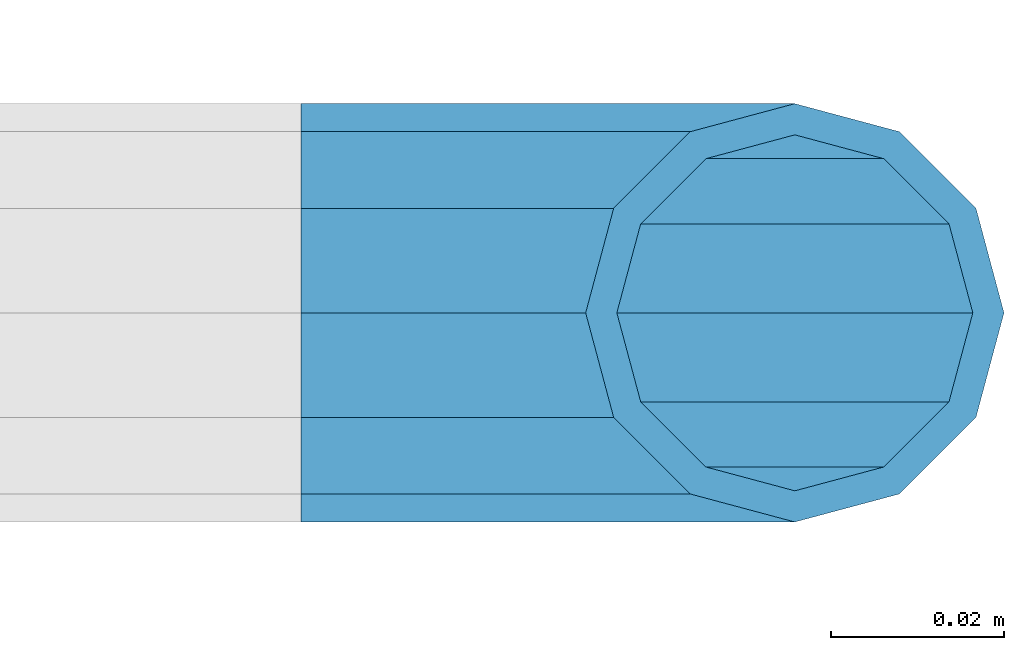
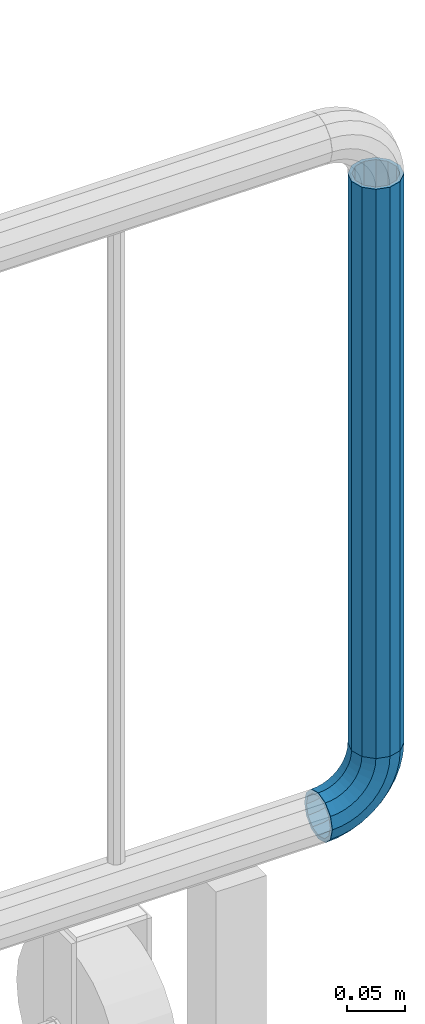
# One storey, part 165 of 247: 1 beam, 1 member.
"""IFC2X3 building model written with IfcOpenShell, lengths in millimetres."""

from ifc_helpers import new_model, si_unit, frame, origin_with_axes, place, context, subcontext, project, spatial, faceted_brep, material, type_object, element, save


model = new_model("IFC2X3")

# Units and contexts
model_context = context("Model", 3, precision=1e-05, world=origin_with_axes())
body_context = subcontext(model_context, "Body", "Model", "MODEL_VIEW")
ifc_project = project(units=[si_unit("LENGTHUNIT", "METRE", prefix="MILLI"), si_unit("AREAUNIT", "SQUARE_METRE"), si_unit("VOLUMEUNIT", "CUBIC_METRE"), si_unit("MASSUNIT", "GRAM", prefix="KILO"), si_unit("TIMEUNIT", "SECOND"), si_unit("PLANEANGLEUNIT", "RADIAN"), si_unit("SOLIDANGLEUNIT", "STERADIAN"), si_unit("THERMODYNAMICTEMPERATUREUNIT", "DEGREE_CELSIUS"), si_unit("LUMINOUSINTENSITYUNIT", "LUMEN")], contexts=[model_context])

# Site, building, storey
site_placement = place(None, origin_with_axes())
site = spatial("IfcSite", under=ifc_project, at=site_placement, CompositionType="ELEMENT")
building_placement = place(site_placement, origin_with_axes())
building = spatial("IfcBuilding", under=site, at=building_placement, Name="Standard", CompositionType="ELEMENT")
storey_placement = place(building_placement, origin_with_axes())
storey = spatial("IfcBuildingStorey", under=building, at=storey_placement, Name="Undefined", CompositionType="ELEMENT", Elevation=0.0)

# Member
ifc_material = material()
member_type = type_object("IfcMemberType", PredefinedType="NOTDEFINED")
member_placement = place(storey_placement, frame((30329.9462613762, 5941.85337247848, 281.650006544463), z_axis=(0.0, -0.999999999999548, -9.5100000000016e-07), x_axis=(-0.707106773186475, 4.52999999771556e-07, -0.707106789186475)))
element("IfcMember", 1, at=member_placement, inside=storey, type_object=member_type, material=ifc_material, context=body_context, shape_type="Brep", body=[
    faceted_brep([(17.0766287656552, -17.0766287656515, 0.0), (14.7887943220521, -14.7887943220485, -12.0749999999998), (19.0945697419556, -11.1113146999705, -12.0749999999998), (20.9963409898264, -13.7288782624128, 0.0), (8.53831438282941, -8.53831438282577, -20.9145135013941), (13.8988340683936, -3.95999805533575, -20.9145135013941), (0.0, 3.63797880709171e-12, -24.1499999999996), (6.80132714696083, 5.80888215174127, -24.1499999999996), (-8.53831438282577, 8.53831438282941, -20.9145135013941), (-0.296179774468328, 15.5777623588219, -20.9145135013941), (-14.7887943220521, 14.7887943220558, -12.0749999999998), (-5.4919154480267, 22.7290790034531, -12.0749999999998), (-17.0766287656552, 17.0766287656588, 0.0), (-7.39368669590112, 25.3466425658989, 0.0), (-14.7887943220521, 14.7887943220558, 12.0749999999998), (-5.4919154480267, 22.7290790034531, 12.0749999999998), (-8.53831438282577, 8.53831438282941, 20.9145135013941), (-0.296179774468328, 15.5777623588219, 20.9145135013941), (0.0, 3.63797880709171e-12, 24.1499999999996), (6.80132714696083, 5.80888215174127, 24.1499999999996), (8.53831438282941, -8.53831438282577, 20.9145135013941), (13.8988340683936, -3.95999805533575, 20.9145135013941), (14.7887943220521, -14.7887943220485, 12.0749999999998), (19.0945697419556, -11.1113146999705, 12.0749999999998), (14.5310443533854, -14.5310443533817, 0.0), (12.5842535535485, -12.5842535535448, 10.2749999999996), (17.2620366843148, -8.58904933077429, 10.2749999999996), (18.8803140815726, -10.8164170826603, 0.0), (7.26552217669087, -7.26552217668723, 17.7968220477705), (12.8408206142667, -2.50376746545953, 17.7968220477705), (0.0, 3.63797880709171e-12, 20.5500000000002), (6.80132714696083, 5.80888215174127, 20.5500000000002), (-7.26552217669087, 7.2655221766945, 17.7968220477705), (0.761833679654956, 14.1215317689421, 17.7968220477705), (-12.5842535535485, 12.5842535535521, 10.2749999999996), (-3.65938239038951, 20.2068136342532, 10.2749999999996), (-14.5310443533817, 14.5310443533854, 0.0), (-5.27765978764728, 22.4341813861465, 0.0), (-12.5842535535485, 12.5842535535521, -10.2749999999996), (-3.65938239038951, 20.2068136342532, -10.2749999999996), (-7.26552217669087, 7.2655221766945, -17.7968220477705), (0.761833679654956, 14.1215317689421, -17.7968220477705), (0.0, 3.63797880709171e-12, -20.5500000000002), (6.80132714696083, 5.80888215174127, -20.5500000000002), (7.26552217669087, -7.26552217668723, -17.7968220477705), (12.8408206142667, -2.50376746545953, -17.7968220477705), (12.5842535535485, -12.5842535535448, -10.2749999999996), (17.2620366843148, -8.58904933077429, -10.2749999999996), (23.922618478784, -8.15268262886457, -12.0749999999998), (25.3914986111849, -11.0355222080434, 0.0), (19.9095633268335, -0.276618428470101, -20.9145135013941), (14.4276280424783, 10.4822853511068, -24.1499999999996), (8.94569275812319, 21.2411891306838, -20.9145135013941), (4.93263760616901, 29.1172533310746, -12.0749999999998), (3.46375747376806, 32.0000929102534, 0.0), (4.93263760616901, 29.1172533310746, 12.0749999999998), (8.94569275812319, 21.2411891306838, 20.9145135013941), (14.4276280424783, 10.4822853511068, 24.1499999999996), (19.9095633268335, -0.276618428470101, 20.9145135013941), (23.922618478784, -8.15268262886457, 12.0749999999998), (22.5072161777207, -5.37479920327678, 10.2749999999996), (23.7571328121303, -7.82789872096328, 0.0), (19.0923804273007, 1.32719331506814, 17.7968220477705), (14.4276280424783, 10.4822853511068, 20.5500000000002), (9.76287565765597, 19.6373773871455, 17.7968220477705), (6.34803990723594, 26.3393699054905, 10.2749999999996), (5.09812327282998, 28.7924694231733, 0.0), (6.34803990723594, 26.3393699054905, -10.2749999999996), (9.76287565765597, 19.6373773871455, -17.7968220477705), (14.4276280424783, 10.4822853511068, -20.5500000000002), (19.0923804273007, 1.32719331506814, -17.7968220477705), (22.5072161777207, -5.37479920327678, -10.2749999999996), (29.1540579492757, -5.98574944944994, -12.0749999999998), (30.1538782624157, -9.0628799673359, 0.0), (26.4224980553372, 2.42112746692874, -20.9145135013941), (22.6911178482587, 13.9051349011934, -24.1499999999996), (18.9597376411839, 25.3891423354544, -20.9145135013941), (16.228177747249, 33.7960192518367, -12.0749999999998), (15.2283574341054, 36.873149769719, 0.0), (16.228177747249, 33.7960192518367, 12.0749999999998), (18.9597376411839, 25.3891423354544, 20.9145135013941), (22.6911178482587, 13.9051349011934, 24.1499999999996), (26.4224980553372, 2.42112746692874, 20.9145135013941), (29.1540579492757, -5.98574944944994, 12.0749999999998), (28.190638306889, -3.02064867668378, 10.2749999999996), (29.0414170826662, -5.63907650866895, 0.0), (25.8662674654624, 4.13302919626221, 17.7968220477705), (22.6911178482587, 13.9051349011934, 20.5500000000002), (19.5159682310587, 23.6772406061282, 17.7968220477705), (17.1915973896357, 30.8309184790705, 10.2749999999996), (16.3408186138549, 33.4493463110593, 0.0), (17.1915973896357, 30.8309184790705, -10.2749999999996), (19.5159682310587, 23.6772406061282, -17.7968220477705), (22.6911178482587, 13.9051349011934, -20.5500000000002), (25.8662674654624, 4.13302919626221, -17.7968220477705), (28.190638306889, -3.02064867668378, -10.2749999999996), (34.660072751507, -4.66387224825303, -12.0749999999998), (35.1662143510621, -7.85952453907885, 0.0), (33.2772681857023, 4.06681217360529, -20.9145135013941), (31.3883220203388, 15.9931488862931, -24.1499999999996), (29.499375854979, 27.9194855989772, -20.9145135013941), (28.1165712891707, 36.6501700208391, -12.0749999999998), (27.6104296896192, 39.8458223116686, 0.0), (28.1165712891707, 36.6501700208391, 12.0749999999998), (29.499375854979, 27.9194855989772, 20.9145135013941), (31.3883220203388, 15.9931488862931, 24.1499999999996), (33.2772681857023, 4.06681217360529, 20.9145135013941), (34.660072751507, -4.66387224825303, 12.0749999999998), (34.1723583567982, -1.58456474993727, 10.2749999999996), (34.6030502769172, -4.30384651293571, 0.0), (32.995686148628, 5.84465118667504, 17.7968220477705), (31.3883220203388, 15.9931488862931, 20.5500000000002), (29.7809578920533, 26.1416465859074, 17.7968220477705), (28.6042856838794, 33.5708625225234, 10.2749999999996), (28.1735937637641, 36.2901442855255, 0.0), (28.6042856838794, 33.5708625225234, -10.2749999999996), (29.7809578920533, 26.1416465859074, -17.7968220477705), (31.3883220203388, 15.9931488862931, -20.5500000000002), (32.995686148628, 5.84465118667504, -17.7968220477705), (34.1723583567982, -1.58456474993727, -10.2749999999996), (40.3050865276309, -4.21960002902415, -12.0749999999998), (40.3050865276346, -7.45508652763237, 0.0), (40.3050865276309, 4.61991347236835, -20.9145135013941), (40.3050865276346, 16.6949134723691, -24.1499999999996), (40.3050865276309, 28.7699134723698, -20.9145135013941), (40.3050865276309, 37.6094269737623, -12.0749999999998), (40.3050865276346, 40.8449134723705, 0.0), (40.3050865276309, 37.6094269737623, 12.0749999999998), (40.3050865276309, 28.7699134723698, 20.9145135013941), (40.3050865276346, 16.6949134723691, 24.1499999999996), (40.3050865276309, 4.61991347236835, 20.9145135013941), (40.3050865276309, -4.21960002902415, 12.0749999999998), (40.3050865276346, -1.10190857540147, 10.2749999999996), (40.3050865276309, -3.85508652763019, 0.0), (40.3050865276346, 6.41991347236763, 17.7968220477705), (40.3050865276346, 16.6949134723691, 20.5500000000002), (40.3050865276346, 26.9699134723705, 17.7968220477705), (40.3050865276346, 34.4917355201396, 10.2749999999996), (40.3050865276309, 37.2449134723684, 0.0), (40.3050865276346, 34.4917355201396, -10.2749999999996), (40.3050865276346, 26.9699134723705, -17.7968220477705), (40.3050865276346, 16.6949134723691, -20.5500000000002), (40.3050865276346, 6.41991347236763, -17.7968220477705), (40.3050865276346, -1.10190857540147, -10.2749999999996), (45.9501003037585, -4.66387224825667, -12.0749999999998), (45.443958704207, -7.85952453907885, 0.0), (47.3329048695668, 4.06681217360529, -20.9145135013941), (49.2218510349267, 15.9931488862894, -24.1499999999996), (51.1107972002865, 27.9194855989808, -20.9145135013941), (52.4936017660912, 36.6501700208391, -12.0749999999998), (52.9997433656463, 39.845822311665, 0.0), (52.4936017660912, 36.6501700208391, 12.0749999999998), (51.1107972002865, 27.9194855989808, 20.9145135013941), (49.2218510349267, 15.9931488862894, 24.1499999999996), (47.3329048695668, 4.06681217360529, 20.9145135013941), (45.9501003037585, -4.66387224825667, 12.0749999999998), (46.4378146984673, -1.58456474993363, 10.2749999999996), (46.0071227783483, -4.30384651293934, 0.0), (47.6144869066338, 5.84465118667504, 17.7968220477705), (49.2218510349267, 15.9931488862894, 20.5500000000002), (50.8292151632122, 26.1416465859038, 17.7968220477705), (52.0058873713861, 33.5708625225197, 10.2749999999996), (52.4365792915014, 36.2901442855218, 0.0), (52.0058873713861, 33.5708625225197, -10.2749999999996), (50.8292151632122, 26.1416465859038, -17.7968220477705), (49.2218510349267, 15.9931488862894, -20.5500000000002), (47.6144869066338, 5.84465118667504, -17.7968220477705), (46.4378146984673, -1.58456474993363, -10.2749999999996), (51.4561151059934, -5.98574944944994, -12.0749999999998), (50.4562947928498, -9.06287996733226, 0.0), (54.1876749999246, 2.42112746692874, -20.9145135013941), (57.9190552070031, 13.9051349011934, -24.1499999999996), (61.6504354140816, 25.389142335458, -20.9145135013941), (64.3819953080201, 33.7960192518367, -12.0749999999998), (65.3818156211564, 36.873149769719, 0.0), (64.3819953080201, 33.7960192518367, 12.0749999999998), (61.6504354140816, 25.389142335458, 20.9145135013941), (57.9190552070031, 13.9051349011934, 24.1499999999996), (54.1876749999246, 2.42112746692874, 20.9145135013941), (51.4561151059934, -5.98574944944994, 12.0749999999998), (52.4195347483801, -3.02064867668378, 10.2749999999996), (51.5687559725993, -5.63907650867259, 0.0), (54.743905589803, 4.13302919625858, 17.7968220477705), (57.9190552070031, 13.9051349011934, 20.5500000000002), (61.0942048242068, 23.6772406061245, 17.7968220477705), (63.4185756656334, 30.8309184790705, 10.2749999999996), (64.2693544414105, 33.4493463110557, 0.0), (63.4185756656334, 30.8309184790705, -10.2749999999996), (61.0942048242068, 23.6772406061245, -17.7968220477705), (57.9190552070031, 13.9051349011934, -20.5500000000002), (54.743905589803, 4.13302919625858, -17.7968220477705), (52.4195347483801, -3.02064867668378, -10.2749999999996), (56.6875545764815, -8.15268262886093, -12.0749999999998), (55.2186744440769, -11.0355222080434, 0.0), (60.700609728432, -0.276618428466463, -20.9145135013941), (66.1825450127908, 10.4822853511068, -24.1499999999996), (71.6644802971423, 21.2411891306801, -20.9145135013941), (75.6775354490928, 29.1172533310746, -12.0749999999998), (77.1464155814938, 32.0000929102534, 0.0), (75.6775354490928, 29.1172533310746, 12.0749999999998), (71.6644802971423, 21.2411891306801, 20.9145135013941), (66.1825450127908, 10.4822853511068, 24.1499999999996), (60.700609728432, -0.276618428466463, 20.9145135013941), (56.6875545764815, -8.15268262886093, 12.0749999999998), (58.1029568775448, -5.37479920327314, 10.2749999999996), (56.8530402431388, -7.82789872096328, 0.0), (61.5177926279612, 1.32719331506814, 17.7968220477705), (66.1825450127908, 10.4822853511068, 20.5500000000002), (70.8472973976095, 19.6373773871419, 17.7968220477705), (74.2621331480295, 26.3393699054868, 10.2749999999996), (75.5120497824355, 28.792469423177, 0.0), (74.2621331480295, 26.3393699054868, -10.2749999999996), (70.8472973976095, 19.6373773871419, -17.7968220477705), (66.1825450127908, 10.4822853511068, -20.5500000000002), (61.5177926279612, 1.32719331506814, -17.7968220477705), (58.1029568775448, -5.37479920327314, -10.2749999999996), (61.5156033133135, -11.1113146999705, -12.0749999999998), (59.6138320654427, -13.7288782624128, 0.0), (66.7113389868719, -3.95999805533938, -20.9145135013941), (73.8088459083046, 5.80888215174491, -24.1499999999996), (80.9063528297338, 15.5777623588183, -20.9145135013941), (86.1020885032958, 22.7290790034531, -12.0749999999998), (88.0038597511666, 25.3466425658953, 0.0), (86.1020885032958, 22.7290790034531, 12.0749999999998), (80.9063528297338, 15.5777623588183, 20.9145135013941), (73.8088459083046, 5.80888215174491, 24.1499999999996), (66.7113389868719, -3.95999805533938, 20.9145135013941), (61.5156033133135, -11.1113146999705, 12.0749999999998), (63.3481363709507, -8.58904933077065, 10.2749999999996), (61.7298589736929, -10.816417082664, 0.0), (67.7693524410024, -2.50376746545953, 17.7968220477705), (73.8088459083046, 5.80888215174491, 20.5500000000002), (79.8483393756105, 14.1215317689457, 17.7968220477705), (84.2695554456586, 20.2068136342532, 10.2749999999996), (85.8878328429164, 22.4341813861465, 0.0), (84.2695554456586, 20.2068136342532, -10.2749999999996), (79.8483393756105, 14.1215317689457, -17.7968220477705), (73.8088459083046, 5.80888215174491, -20.5500000000002), (67.7693524410024, -2.50376746545953, -17.7968220477705), (63.3481363709507, -8.58904933077065, -10.2749999999996), (65.8213787332134, -14.7887943220521, -12.0749999999998), (63.5335442896103, -17.0766287656552, 0.0), (72.0718586724397, -8.53831438282577, -20.9145135013941), (80.6101730552655, 0.0, -24.1499999999996), (89.1484874380949, 8.53831438282941, -20.9145135013941), (95.3989673773212, 14.7887943220558, -12.0749999999998), (97.6868018209243, 17.0766287656588, 0.0), (95.3989673773212, 14.7887943220558, 12.0749999999998), (89.1484874380949, 8.53831438282941, 20.9145135013941), (80.6101730552655, 0.0, 24.1499999999996), (72.0718586724397, -8.53831438282577, 20.9145135013941), (65.8213787332134, -14.7887943220521, 12.0749999999998), (68.025919501717, -12.5842535535485, 10.2749999999996), (66.0791287018837, -14.5310443533817, 0.0), (73.3446508785746, -7.26552217669087, 17.7968220477705), (80.6101730552655, 0.0, 20.5500000000002), (87.87569523196, 7.2655221766945, 17.7968220477705), (93.1944266088176, 12.5842535535521, 10.2749999999996), (95.1412174086508, 14.5310443533854, 0.0), (93.1944266088176, 12.5842535535521, -10.2749999999996), (87.87569523196, 7.2655221766945, -17.7968220477705), (80.6101730552655, 0.0, -20.5500000000002), (73.3446508785746, -7.26552217669087, -17.7968220477705), (68.025919501717, -12.5842535535485, -10.2749999999996)], [[[0, 1, 2, 3]], [[1, 4, 5, 2]], [[4, 6, 7, 5]], [[6, 8, 9, 7]], [[8, 10, 11, 9]], [[10, 12, 13, 11]], [[12, 14, 15, 13]], [[14, 16, 17, 15]], [[16, 18, 19, 17]], [[18, 20, 21, 19]], [[20, 22, 23, 21]], [[22, 0, 3, 23]], [[24, 25, 26, 27]], [[25, 28, 29, 26]], [[28, 30, 31, 29]], [[30, 32, 33, 31]], [[32, 34, 35, 33]], [[34, 36, 37, 35]], [[36, 38, 39, 37]], [[38, 40, 41, 39]], [[40, 42, 43, 41]], [[42, 44, 45, 43]], [[44, 46, 47, 45]], [[46, 24, 27, 47]], [[22, 20, 18, 16, 14, 12, 10, 8, 6, 4, 1, 0], [46, 44, 42, 40, 38, 36, 34, 32, 30, 28, 25, 24]], [[3, 2, 48, 49]], [[2, 5, 50, 48]], [[5, 7, 51, 50]], [[7, 9, 52, 51]], [[9, 11, 53, 52]], [[11, 13, 54, 53]], [[13, 15, 55, 54]], [[15, 17, 56, 55]], [[17, 19, 57, 56]], [[19, 21, 58, 57]], [[21, 23, 59, 58]], [[23, 3, 49, 59]], [[27, 26, 60, 61]], [[26, 29, 62, 60]], [[29, 31, 63, 62]], [[31, 33, 64, 63]], [[33, 35, 65, 64]], [[35, 37, 66, 65]], [[37, 39, 67, 66]], [[39, 41, 68, 67]], [[41, 43, 69, 68]], [[43, 45, 70, 69]], [[45, 47, 71, 70]], [[47, 27, 61, 71]], [[49, 48, 72, 73]], [[48, 50, 74, 72]], [[50, 51, 75, 74]], [[51, 52, 76, 75]], [[52, 53, 77, 76]], [[53, 54, 78, 77]], [[54, 55, 79, 78]], [[55, 56, 80, 79]], [[56, 57, 81, 80]], [[57, 58, 82, 81]], [[58, 59, 83, 82]], [[59, 49, 73, 83]], [[61, 60, 84, 85]], [[60, 62, 86, 84]], [[62, 63, 87, 86]], [[63, 64, 88, 87]], [[64, 65, 89, 88]], [[65, 66, 90, 89]], [[66, 67, 91, 90]], [[67, 68, 92, 91]], [[68, 69, 93, 92]], [[69, 70, 94, 93]], [[70, 71, 95, 94]], [[71, 61, 85, 95]], [[73, 72, 96, 97]], [[72, 74, 98, 96]], [[74, 75, 99, 98]], [[75, 76, 100, 99]], [[76, 77, 101, 100]], [[77, 78, 102, 101]], [[78, 79, 103, 102]], [[79, 80, 104, 103]], [[80, 81, 105, 104]], [[81, 82, 106, 105]], [[82, 83, 107, 106]], [[83, 73, 97, 107]], [[85, 84, 108, 109]], [[84, 86, 110, 108]], [[86, 87, 111, 110]], [[87, 88, 112, 111]], [[88, 89, 113, 112]], [[89, 90, 114, 113]], [[90, 91, 115, 114]], [[91, 92, 116, 115]], [[92, 93, 117, 116]], [[93, 94, 118, 117]], [[94, 95, 119, 118]], [[95, 85, 109, 119]], [[97, 96, 120, 121]], [[96, 98, 122, 120]], [[98, 99, 123, 122]], [[99, 100, 124, 123]], [[100, 101, 125, 124]], [[101, 102, 126, 125]], [[102, 103, 127, 126]], [[103, 104, 128, 127]], [[104, 105, 129, 128]], [[105, 106, 130, 129]], [[106, 107, 131, 130]], [[107, 97, 121, 131]], [[109, 108, 132, 133]], [[108, 110, 134, 132]], [[110, 111, 135, 134]], [[111, 112, 136, 135]], [[112, 113, 137, 136]], [[113, 114, 138, 137]], [[114, 115, 139, 138]], [[115, 116, 140, 139]], [[116, 117, 141, 140]], [[117, 118, 142, 141]], [[118, 119, 143, 142]], [[119, 109, 133, 143]], [[121, 120, 144, 145]], [[120, 122, 146, 144]], [[122, 123, 147, 146]], [[123, 124, 148, 147]], [[124, 125, 149, 148]], [[125, 126, 150, 149]], [[126, 127, 151, 150]], [[127, 128, 152, 151]], [[128, 129, 153, 152]], [[129, 130, 154, 153]], [[130, 131, 155, 154]], [[131, 121, 145, 155]], [[133, 132, 156, 157]], [[132, 134, 158, 156]], [[134, 135, 159, 158]], [[135, 136, 160, 159]], [[136, 137, 161, 160]], [[137, 138, 162, 161]], [[138, 139, 163, 162]], [[139, 140, 164, 163]], [[140, 141, 165, 164]], [[141, 142, 166, 165]], [[142, 143, 167, 166]], [[143, 133, 157, 167]], [[145, 144, 168, 169]], [[144, 146, 170, 168]], [[146, 147, 171, 170]], [[147, 148, 172, 171]], [[148, 149, 173, 172]], [[149, 150, 174, 173]], [[150, 151, 175, 174]], [[151, 152, 176, 175]], [[152, 153, 177, 176]], [[153, 154, 178, 177]], [[154, 155, 179, 178]], [[155, 145, 169, 179]], [[157, 156, 180, 181]], [[156, 158, 182, 180]], [[158, 159, 183, 182]], [[159, 160, 184, 183]], [[160, 161, 185, 184]], [[161, 162, 186, 185]], [[162, 163, 187, 186]], [[163, 164, 188, 187]], [[164, 165, 189, 188]], [[165, 166, 190, 189]], [[166, 167, 191, 190]], [[167, 157, 181, 191]], [[169, 168, 192, 193]], [[168, 170, 194, 192]], [[170, 171, 195, 194]], [[171, 172, 196, 195]], [[172, 173, 197, 196]], [[173, 174, 198, 197]], [[174, 175, 199, 198]], [[175, 176, 200, 199]], [[176, 177, 201, 200]], [[177, 178, 202, 201]], [[178, 179, 203, 202]], [[179, 169, 193, 203]], [[181, 180, 204, 205]], [[180, 182, 206, 204]], [[182, 183, 207, 206]], [[183, 184, 208, 207]], [[184, 185, 209, 208]], [[185, 186, 210, 209]], [[186, 187, 211, 210]], [[187, 188, 212, 211]], [[188, 189, 213, 212]], [[189, 190, 214, 213]], [[190, 191, 215, 214]], [[191, 181, 205, 215]], [[193, 192, 216, 217]], [[192, 194, 218, 216]], [[194, 195, 219, 218]], [[195, 196, 220, 219]], [[196, 197, 221, 220]], [[197, 198, 222, 221]], [[198, 199, 223, 222]], [[199, 200, 224, 223]], [[200, 201, 225, 224]], [[201, 202, 226, 225]], [[202, 203, 227, 226]], [[203, 193, 217, 227]], [[205, 204, 228, 229]], [[204, 206, 230, 228]], [[206, 207, 231, 230]], [[207, 208, 232, 231]], [[208, 209, 233, 232]], [[209, 210, 234, 233]], [[210, 211, 235, 234]], [[211, 212, 236, 235]], [[212, 213, 237, 236]], [[213, 214, 238, 237]], [[214, 215, 239, 238]], [[215, 205, 229, 239]], [[217, 216, 240, 241]], [[216, 218, 242, 240]], [[218, 219, 243, 242]], [[219, 220, 244, 243]], [[220, 221, 245, 244]], [[221, 222, 246, 245]], [[222, 223, 247, 246]], [[223, 224, 248, 247]], [[224, 225, 249, 248]], [[225, 226, 250, 249]], [[226, 227, 251, 250]], [[227, 217, 241, 251]], [[229, 228, 252, 253]], [[228, 230, 254, 252]], [[230, 231, 255, 254]], [[231, 232, 256, 255]], [[232, 233, 257, 256]], [[233, 234, 258, 257]], [[234, 235, 259, 258]], [[235, 236, 260, 259]], [[236, 237, 261, 260]], [[237, 238, 262, 261]], [[238, 239, 263, 262]], [[239, 229, 253, 263]], [[242, 243, 244, 245, 246, 247, 248, 249, 250, 251, 241, 240], [254, 255, 256, 257, 258, 259, 260, 261, 262, 263, 253, 252]]]),
])

# Beam
beam_type = type_object("IfcBeamType", PredefinedType="NOTDEFINED")
beam_placement = place(storey_placement, frame((30329.9462613762, 5941.85337247848, 878.350006544462), z_axis=(1.0, 0.0, 0.0), x_axis=(0.0, 0.0, -1.0)))
element("IfcBeam", 2, at=beam_placement, inside=storey, type_object=beam_type, material=ifc_material, context=body_context, shape_type="Brep", body=[
    faceted_brep([(0.0, -20.5500000000002, 0.0), (0.0, -17.7968220477705, 10.2750000000015), (596.700000000001, -17.7968220477705, 10.2750000000015), (596.700000000001, -20.5500000000002, 0.0), (0.0, -10.2749999999996, 17.7968220477705), (596.700000000001, -10.2749999999996, 17.7968220477705), (0.0, 3.63797880709171e-12, 20.5500000000002), (596.700000000001, 0.0, 20.5499999999993), (0.0, 10.2749999999996, 17.7968220477705), (596.700000000001, 10.2749999999996, 17.7968220477705), (0.0, 17.7968220477705, 10.2750000000015), (596.700000000001, 17.7968220477705, 10.2750000000015), (0.0, 20.5500000000002, 0.0), (596.700000000001, 20.5500000000002, 0.0), (0.0, 17.7968220477705, -10.2750000000015), (596.700000000001, 17.7968220477705, -10.2750000000015), (0.0, 10.2749999999996, -17.7968220477705), (596.700000000001, 10.2749999999996, -17.7968220477705), (0.0, 3.63797880709171e-12, -20.5500000000002), (596.700000000001, 0.0, -20.5499999999993), (0.0, -10.2749999999996, -17.7968220477705), (596.700000000001, -10.2749999999996, -17.7968220477705), (0.0, -17.7968220477705, -10.2750000000015), (596.700000000001, -17.7968220477705, -10.2750000000015), (0.0, -24.1499999999996, 0.0), (0.0, -20.9145135013941, -12.0750000000007), (596.700000000001, -20.9145135013941, -12.0750000000007), (596.700000000001, -24.1499999999996, 0.0), (0.0, -12.0749999999998, -20.9145135013932), (596.700000000001, -12.0749999999998, -20.9145135013932), (0.0, 3.63797880709171e-12, -24.1499999999996), (596.700000000001, 0.0, -24.1500000000015), (0.0, 12.0749999999998, -20.9145135013932), (596.700000000001, 12.0749999999998, -20.9145135013932), (0.0, 20.9145135013941, -12.0750000000007), (596.700000000001, 20.9145135013941, -12.0750000000007), (0.0, 24.1499999999996, 0.0), (596.700000000001, 24.1499999999996, 0.0), (0.0, 20.9145135013941, 12.0750000000007), (596.700000000001, 20.9145135013941, 12.0750000000007), (0.0, 12.0749999999998, 20.9145135013932), (596.700000000001, 12.0749999999998, 20.9145135013932), (0.0, 3.63797880709171e-12, 24.1499999999996), (596.700000000001, 0.0, 24.1500000000015), (0.0, -12.0749999999998, 20.9145135013932), (596.700000000001, -12.0749999999998, 20.9145135013932), (0.0, -20.9145135013941, 12.0750000000007), (596.700000000001, -20.9145135013941, 12.0750000000007)], [[[0, 1, 2, 3]], [[1, 4, 5, 2]], [[4, 6, 7, 5]], [[6, 8, 9, 7]], [[8, 10, 11, 9]], [[10, 12, 13, 11]], [[12, 14, 15, 13]], [[14, 16, 17, 15]], [[16, 18, 19, 17]], [[18, 20, 21, 19]], [[20, 22, 23, 21]], [[22, 0, 3, 23]], [[24, 25, 26, 27]], [[25, 28, 29, 26]], [[28, 30, 31, 29]], [[30, 32, 33, 31]], [[32, 34, 35, 33]], [[34, 36, 37, 35]], [[36, 38, 39, 37]], [[38, 40, 41, 39]], [[40, 42, 43, 41]], [[42, 44, 45, 43]], [[44, 46, 47, 45]], [[46, 24, 27, 47]], [[29, 31, 33, 35, 37, 39, 41, 43, 45, 47, 27, 26], [5, 7, 9, 11, 13, 15, 17, 19, 21, 23, 3, 2]], [[46, 44, 42, 40, 38, 36, 34, 32, 30, 28, 25, 24], [22, 20, 18, 16, 14, 12, 10, 8, 6, 4, 1, 0]]]),
])

save(model, "model.ifc")
